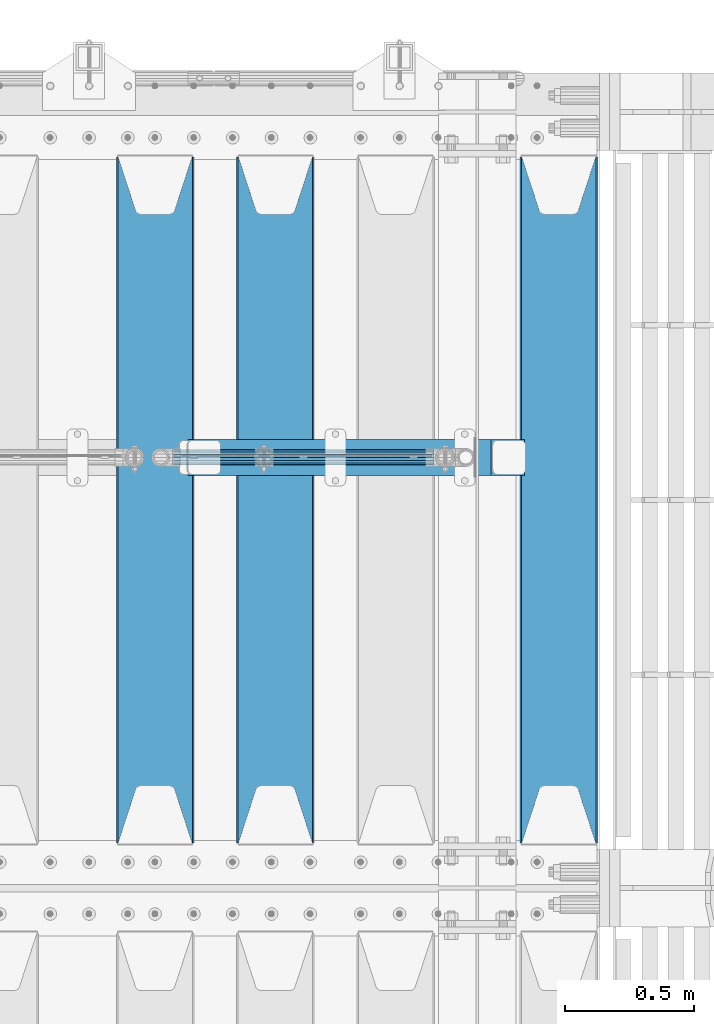
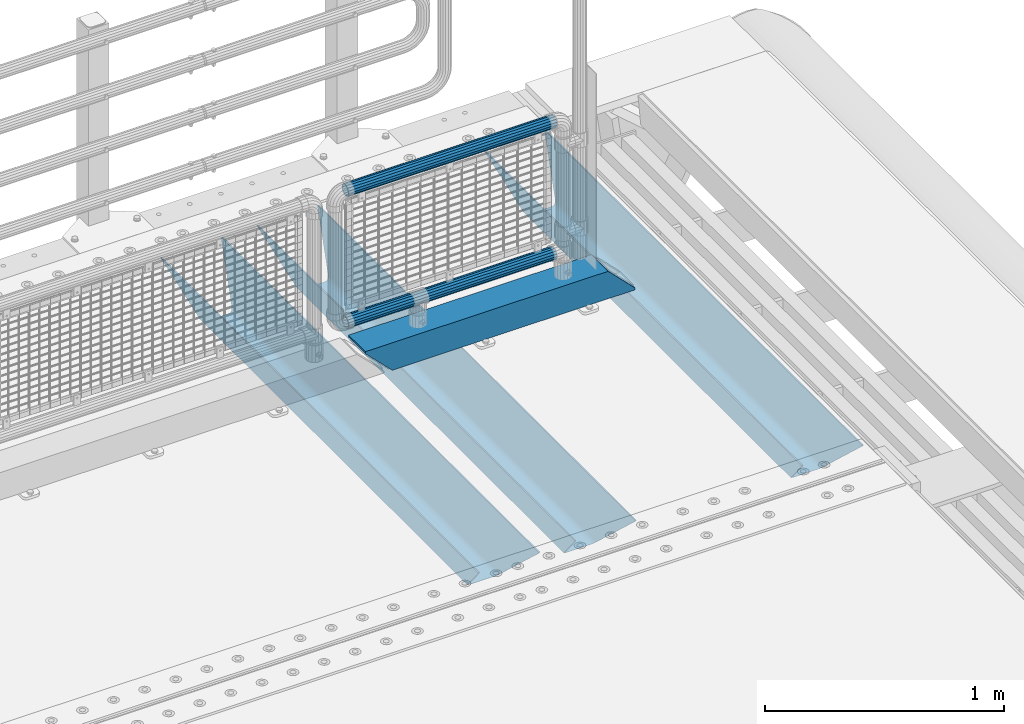
# One storey, part 134 of 257: 6 beams.
"""IFC2X3 building model written with IfcOpenShell, lengths in millimetres."""

from ifc_helpers import new_model, si_unit, frame, origin_with_axes, place, context, subcontext, project, spatial, faceted_brep, material, type_object, element, save


model = new_model("IFC2X3")

# Units and contexts
model_context = context("Model", 3, precision=1e-05, world=origin_with_axes())
body_context = subcontext(model_context, "Body", "Model", "MODEL_VIEW")
ifc_project = project(units=[si_unit("LENGTHUNIT", "METRE", prefix="MILLI"), si_unit("AREAUNIT", "SQUARE_METRE"), si_unit("VOLUMEUNIT", "CUBIC_METRE"), si_unit("MASSUNIT", "GRAM", prefix="KILO"), si_unit("TIMEUNIT", "SECOND"), si_unit("PLANEANGLEUNIT", "RADIAN"), si_unit("SOLIDANGLEUNIT", "STERADIAN"), si_unit("THERMODYNAMICTEMPERATUREUNIT", "DEGREE_CELSIUS"), si_unit("LUMINOUSINTENSITYUNIT", "LUMEN")], contexts=[model_context])

# Site, building, storey
site_placement = place(None, origin_with_axes())
site = spatial("IfcSite", under=ifc_project, at=site_placement, CompositionType="ELEMENT")
building_placement = place(site_placement, origin_with_axes())
building = spatial("IfcBuilding", under=site, at=building_placement, Name="Standard", CompositionType="ELEMENT")
storey_placement = place(building_placement, origin_with_axes())
storey = spatial("IfcBuildingStorey", under=building, at=storey_placement, Name="Undefined", CompositionType="ELEMENT", Elevation=0.0)

# Beams
ifc_material_1 = material(Name="STEEL/S355N")
beam_type_1 = type_object("IfcBeamType", PredefinedType="NOTDEFINED")
beam_1_placement = place(storey_placement, frame((59110.0, 9175.0, -115.0), z_axis=(0.0, 0.0, 1.0), x_axis=(0.0, 1.0, 0.0)))
element("IfcBeam", 1, at=beam_1_placement, inside=storey, type_object=beam_type_1, material=ifc_material_1, context=body_context, shape_type="Brep", body=[
    faceted_brep([(0.0, 150.0, 115.0), (0.0, 143.690000000002, 115.0), (2650.00000000297, 143.690000000002, 115.0), (2650.00000000297, 150.0, 115.0), (2650.00000000297, 142.059565218406, 110.0000000031), (2650.00000000297, 148.369565218403, 110.0000000031), (2441.90079219208, -80.1103600731149, -98.0992078077845), (2437.7588105432, -77.5672621345584, -102.241189456673), (2434.06523489746, -74.4080125315522, -105.934765102404), (2430.91086095089, -70.7102721255724, -109.089139048974), (2428.37322971128, -66.5649389910031, -111.626770288588), (2426.51472138055, -62.0739139532889, -113.485278619323), (2425.38102192091, -57.3475956567636, -114.618978078955), (2424.99999999987, -52.5021667386536, -115.0), (2424.99999999987, 52.5021667386536, -115.0), (2425.38102192091, 57.3475956567636, -114.618978078955), (2426.51472138055, 62.0739139532889, -113.485278619323), (2428.37322971128, 66.5649389910031, -111.626770288588), (2430.91086095089, 70.7102721255724, -109.089139048974), (2434.06523489746, 74.4080125315522, -105.934765102404), (2437.7588105432, 77.5672621345584, -102.241189456673), (2441.90079219208, 80.1103600731149, -98.0992078077846), (2446.38936140511, 81.9747917625791, -93.6106385947584), (2448.24948500409, 76.2713538057287, -91.7505149957729), (2444.62967112262, 74.76777986261, -95.3703288772456), (2441.28936334126, 72.7168944282894, -98.710636658607), (2438.31067330438, 70.1691124903809, -101.689326695487), (2435.76682334747, 67.1870637758839, -104.233176652398), (2433.72034654133, 63.8440531834931, -106.279653458539), (2432.22154950041, 60.2222587982324, -107.778450499454), (2431.30727574265, 56.4107117849126, -108.692724257221), (2430.99999999987, 52.5031078186876, -109.0), (2430.99999999987, -52.5031078186876, -109.0), (2431.30727574265, -56.4107117849126, -108.692724257221), (2432.22154950041, -60.2222587982324, -107.778450499454), (2433.72034654133, -63.8440531834931, -106.279653458539), (2435.76682334747, -67.1870637758839, -104.233176652398), (2438.31067330438, -70.1691124903809, -101.689326695487), (2441.28936334126, -72.7168944282894, -98.7106366586071), (2444.62967112262, -74.76777986261, -95.3703288772457), (2448.24948500409, -76.2713538057287, -91.7505149957729), (2650.00000000297, -142.059565218406, 110.0000000031), (2650.00000000297, -148.369565218403, 110.0000000031), (2446.38936140511, -81.9747917625791, -93.6106385947584), (2650.00000000297, -143.690000000002, 115.0), (2650.00000000297, -150.0, 115.0), (0.0, -143.690000000002, 115.0), (0.0, -150.0, 115.0), (0.0, -148.369565218258, 110.000000002662), (203.61063859742, -81.9747917625791, -93.6106385947584), (208.099207810447, -80.1103600731149, -98.0992078077845), (212.241189459335, -77.5672621345584, -102.241189456673), (215.934765105066, -74.4080125315522, -105.934765102404), (219.089139051636, -70.7102721255724, -109.089139048974), (221.626770291251, -66.5649389910031, -111.626770288588), (223.485278621985, -62.0739139532889, -113.485278619323), (224.618978081617, -57.3475956567636, -114.618978078955), (225.000000002662, -52.5021667386536, -115.0), (225.000000002662, 52.5021667386536, -115.0), (224.618978081617, 57.3475956567636, -114.618978078955), (223.485278621985, 62.0739139532889, -113.485278619323), (221.626770291251, 66.5649389910031, -111.626770288588), (219.089139051636, 70.7102721255724, -109.089139048974), (215.934765105066, 74.4080125315522, -105.934765102404), (212.241189459335, 77.5672621345584, -102.241189456673), (208.099207810447, 80.1103600731149, -98.0992078077846), (203.61063859742, 81.9747917625791, -93.6106385947584), (0.0, 148.369565218258, 110.000000002662), (0.0, 142.05956521826, 110.000000002662), (201.750514998435, 76.2713538057287, -91.7505149957729), (205.370328879908, 74.76777986261, -95.3703288772456), (208.710636661269, 72.7168944282894, -98.710636658607), (211.689326698149, 70.1691124903809, -101.689326695487), (214.233176655061, 67.1870637758839, -104.233176652398), (216.279653461201, 63.8440531834931, -106.279653458539), (217.778450502116, 60.2222587982324, -107.778450499454), (218.692724259884, 56.4107117849126, -108.692724257221), (219.000000002662, 52.5031078186876, -109.0), (219.000000002662, -52.5031078186876, -109.0), (218.692724259884, -56.4107117849126, -108.692724257221), (217.778450502116, -60.2222587982324, -107.778450499454), (216.279653461201, -63.8440531834931, -106.279653458539), (214.233176655061, -67.1870637758839, -104.233176652398), (211.689326698149, -70.1691124903809, -101.689326695487), (208.710636661269, -72.7168944282894, -98.7106366586071), (205.370328879908, -74.76777986261, -95.3703288772457), (201.750514998435, -76.2713538057287, -91.7505149957729), (0.0, -142.05956521826, 110.000000002662)], [[[0, 1, 2, 3]], [[3, 2, 4, 5]], [[6, 7, 8, 9, 10, 11, 12, 13, 14, 15, 16, 17, 18, 19, 20, 21, 22, 5, 4, 23, 24, 25, 26, 27, 28, 29, 30, 31, 32, 33, 34, 35, 36, 37, 38, 39, 40, 41, 42, 43]], [[44, 45, 42, 41]], [[46, 47, 45, 44]], [[43, 42, 45, 47, 48, 49]], [[6, 43, 49, 50]], [[7, 6, 50, 51]], [[8, 7, 51, 52]], [[9, 8, 52, 53]], [[10, 9, 53, 54]], [[11, 10, 54, 55]], [[12, 11, 55, 56]], [[13, 12, 56, 57]], [[14, 13, 57, 58]], [[15, 14, 58, 59]], [[16, 15, 59, 60]], [[17, 16, 60, 61]], [[18, 17, 61, 62]], [[19, 18, 62, 63]], [[20, 19, 63, 64]], [[21, 20, 64, 65]], [[22, 21, 65, 66]], [[0, 3, 5, 22, 66, 67]], [[1, 0, 67, 68]], [[23, 4, 2, 1, 68, 69]], [[24, 23, 69, 70]], [[25, 24, 70, 71]], [[26, 25, 71, 72]], [[27, 26, 72, 73]], [[28, 27, 73, 74]], [[29, 28, 74, 75]], [[30, 29, 75, 76]], [[31, 30, 76, 77]], [[32, 31, 77, 78]], [[33, 32, 78, 79]], [[34, 33, 79, 80]], [[35, 34, 80, 81]], [[36, 35, 81, 82]], [[37, 36, 82, 83]], [[38, 37, 83, 84]], [[39, 38, 84, 85]], [[40, 39, 85, 86]], [[46, 44, 41, 40, 86, 87]], [[47, 46, 87, 48]], [[86, 85, 84, 83, 82, 81, 80, 79, 78, 77, 76, 75, 74, 73, 72, 71, 70, 69, 68, 67, 66, 65, 64, 63, 62, 61, 60, 59, 58, 57, 56, 55, 54, 53, 52, 51, 50, 49, 48, 87]]]),
])
beam_2_placement = place(storey_placement, frame((58015.0, 9175.0, -115.0), z_axis=(0.0, 0.0, 1.0), x_axis=(0.0, 1.0, 0.0)))
element("IfcBeam", 2, at=beam_2_placement, inside=storey, type_object=beam_type_1, material=ifc_material_1, context=body_context, shape_type="Brep", body=[
    faceted_brep([(0.0, 150.0, 115.0), (0.0, 143.690000000002, 115.0), (2650.00000000297, 143.690000000002, 115.0), (2650.00000000297, 150.0, 115.0), (2650.00000000297, 142.059565218406, 110.0000000031), (2650.00000000297, 148.369565218403, 110.0000000031), (2441.90079219208, -80.1103600731149, -98.0992078077845), (2437.7588105432, -77.5672621345584, -102.241189456673), (2434.06523489746, -74.4080125315522, -105.934765102404), (2430.91086095089, -70.7102721255724, -109.089139048974), (2428.37322971128, -66.5649389910031, -111.626770288588), (2426.51472138055, -62.0739139532889, -113.485278619323), (2425.38102192091, -57.3475956567636, -114.618978078955), (2424.99999999987, -52.5021667386536, -115.0), (2424.99999999987, 52.5021667386536, -115.0), (2425.38102192091, 57.3475956567636, -114.618978078955), (2426.51472138055, 62.0739139532889, -113.485278619323), (2428.37322971128, 66.5649389910031, -111.626770288588), (2430.91086095089, 70.7102721255724, -109.089139048974), (2434.06523489746, 74.4080125315522, -105.934765102404), (2437.7588105432, 77.5672621345584, -102.241189456673), (2441.90079219208, 80.1103600731149, -98.0992078077846), (2446.38936140511, 81.9747917625791, -93.6106385947584), (2448.24948500409, 76.2713538057287, -91.7505149957729), (2444.62967112262, 74.76777986261, -95.3703288772456), (2441.28936334126, 72.7168944282894, -98.710636658607), (2438.31067330438, 70.1691124903809, -101.689326695487), (2435.76682334747, 67.1870637758839, -104.233176652398), (2433.72034654133, 63.8440531834931, -106.279653458539), (2432.22154950041, 60.2222587982324, -107.778450499454), (2431.30727574265, 56.4107117849126, -108.692724257221), (2430.99999999987, 52.5031078186876, -109.0), (2430.99999999987, -52.5031078186876, -109.0), (2431.30727574265, -56.4107117849126, -108.692724257221), (2432.22154950041, -60.2222587982324, -107.778450499454), (2433.72034654133, -63.8440531834931, -106.279653458539), (2435.76682334747, -67.1870637758839, -104.233176652398), (2438.31067330438, -70.1691124903809, -101.689326695487), (2441.28936334126, -72.7168944282894, -98.7106366586071), (2444.62967112262, -74.76777986261, -95.3703288772457), (2448.24948500409, -76.2713538057287, -91.7505149957729), (2650.00000000297, -142.059565218406, 110.0000000031), (2650.00000000297, -148.369565218403, 110.0000000031), (2446.38936140511, -81.9747917625791, -93.6106385947584), (2650.00000000297, -143.690000000002, 115.0), (2650.00000000297, -150.0, 115.0), (0.0, -143.690000000002, 115.0), (0.0, -150.0, 115.0), (0.0, -148.369565218258, 110.000000002662), (203.61063859742, -81.9747917625791, -93.6106385947584), (208.099207810447, -80.1103600731149, -98.0992078077845), (212.241189459335, -77.5672621345584, -102.241189456673), (215.934765105066, -74.4080125315522, -105.934765102404), (219.089139051636, -70.7102721255724, -109.089139048974), (221.626770291251, -66.5649389910031, -111.626770288588), (223.485278621985, -62.0739139532889, -113.485278619323), (224.618978081617, -57.3475956567636, -114.618978078955), (225.000000002662, -52.5021667386536, -115.0), (225.000000002662, 52.5021667386536, -115.0), (224.618978081617, 57.3475956567636, -114.618978078955), (223.485278621985, 62.0739139532889, -113.485278619323), (221.626770291251, 66.5649389910031, -111.626770288588), (219.089139051636, 70.7102721255724, -109.089139048974), (215.934765105066, 74.4080125315522, -105.934765102404), (212.241189459335, 77.5672621345584, -102.241189456673), (208.099207810447, 80.1103600731149, -98.0992078077846), (203.61063859742, 81.9747917625791, -93.6106385947584), (0.0, 148.369565218258, 110.000000002662), (0.0, 142.05956521826, 110.000000002662), (201.750514998435, 76.2713538057287, -91.7505149957729), (205.370328879908, 74.76777986261, -95.3703288772456), (208.710636661269, 72.7168944282894, -98.710636658607), (211.689326698149, 70.1691124903809, -101.689326695487), (214.233176655061, 67.1870637758839, -104.233176652398), (216.279653461201, 63.8440531834931, -106.279653458539), (217.778450502116, 60.2222587982324, -107.778450499454), (218.692724259884, 56.4107117849126, -108.692724257221), (219.000000002662, 52.5031078186876, -109.0), (219.000000002662, -52.5031078186876, -109.0), (218.692724259884, -56.4107117849126, -108.692724257221), (217.778450502116, -60.2222587982324, -107.778450499454), (216.279653461201, -63.8440531834931, -106.279653458539), (214.233176655061, -67.1870637758839, -104.233176652398), (211.689326698149, -70.1691124903809, -101.689326695487), (208.710636661269, -72.7168944282894, -98.7106366586071), (205.370328879908, -74.76777986261, -95.3703288772457), (201.750514998435, -76.2713538057287, -91.7505149957729), (0.0, -142.05956521826, 110.000000002662)], [[[0, 1, 2, 3]], [[3, 2, 4, 5]], [[6, 7, 8, 9, 10, 11, 12, 13, 14, 15, 16, 17, 18, 19, 20, 21, 22, 5, 4, 23, 24, 25, 26, 27, 28, 29, 30, 31, 32, 33, 34, 35, 36, 37, 38, 39, 40, 41, 42, 43]], [[44, 45, 42, 41]], [[46, 47, 45, 44]], [[43, 42, 45, 47, 48, 49]], [[6, 43, 49, 50]], [[7, 6, 50, 51]], [[8, 7, 51, 52]], [[9, 8, 52, 53]], [[10, 9, 53, 54]], [[11, 10, 54, 55]], [[12, 11, 55, 56]], [[13, 12, 56, 57]], [[14, 13, 57, 58]], [[15, 14, 58, 59]], [[16, 15, 59, 60]], [[17, 16, 60, 61]], [[18, 17, 61, 62]], [[19, 18, 62, 63]], [[20, 19, 63, 64]], [[21, 20, 64, 65]], [[22, 21, 65, 66]], [[0, 3, 5, 22, 66, 67]], [[1, 0, 67, 68]], [[23, 4, 2, 1, 68, 69]], [[24, 23, 69, 70]], [[25, 24, 70, 71]], [[26, 25, 71, 72]], [[27, 26, 72, 73]], [[28, 27, 73, 74]], [[29, 28, 74, 75]], [[30, 29, 75, 76]], [[31, 30, 76, 77]], [[32, 31, 77, 78]], [[33, 32, 78, 79]], [[34, 33, 79, 80]], [[35, 34, 80, 81]], [[36, 35, 81, 82]], [[37, 36, 82, 83]], [[38, 37, 83, 84]], [[39, 38, 84, 85]], [[40, 39, 85, 86]], [[46, 44, 41, 40, 86, 87]], [[47, 46, 87, 48]], [[86, 85, 84, 83, 82, 81, 80, 79, 78, 77, 76, 75, 74, 73, 72, 71, 70, 69, 68, 67, 66, 65, 64, 63, 62, 61, 60, 59, 58, 57, 56, 55, 54, 53, 52, 51, 50, 49, 48, 87]]]),
])
beam_3_placement = place(storey_placement, frame((57550.0, 9175.0, -115.0), z_axis=(0.0, 0.0, 1.0), x_axis=(0.0, 1.0, 0.0)))
element("IfcBeam", 3, at=beam_3_placement, inside=storey, type_object=beam_type_1, material=ifc_material_1, context=body_context, shape_type="Brep", body=[
    faceted_brep([(0.0, 150.0, 115.0), (0.0, 143.690000000002, 115.0), (2650.00000000297, 143.690000000002, 115.0), (2650.00000000297, 150.0, 115.0), (2650.00000000297, 142.059565218406, 110.0000000031), (2650.00000000297, 148.369565218403, 110.0000000031), (2441.90079219208, -80.1103600731149, -98.0992078077845), (2437.7588105432, -77.5672621345584, -102.241189456673), (2434.06523489746, -74.4080125315522, -105.934765102404), (2430.91086095089, -70.7102721255724, -109.089139048974), (2428.37322971128, -66.5649389910031, -111.626770288588), (2426.51472138055, -62.0739139532889, -113.485278619323), (2425.38102192091, -57.3475956567636, -114.618978078955), (2424.99999999987, -52.5021667386536, -115.0), (2424.99999999987, 52.5021667386536, -115.0), (2425.38102192091, 57.3475956567636, -114.618978078955), (2426.51472138055, 62.0739139532889, -113.485278619323), (2428.37322971128, 66.5649389910031, -111.626770288588), (2430.91086095089, 70.7102721255724, -109.089139048974), (2434.06523489746, 74.4080125315522, -105.934765102404), (2437.7588105432, 77.5672621345584, -102.241189456673), (2441.90079219208, 80.1103600731149, -98.0992078077846), (2446.38936140511, 81.9747917625791, -93.6106385947584), (2448.24948500409, 76.2713538057287, -91.7505149957729), (2444.62967112262, 74.76777986261, -95.3703288772456), (2441.28936334126, 72.7168944282894, -98.710636658607), (2438.31067330438, 70.1691124903809, -101.689326695487), (2435.76682334747, 67.1870637758839, -104.233176652398), (2433.72034654133, 63.8440531834931, -106.279653458539), (2432.22154950041, 60.2222587982324, -107.778450499454), (2431.30727574265, 56.4107117849126, -108.692724257221), (2430.99999999987, 52.5031078186876, -109.0), (2430.99999999987, -52.5031078186876, -109.0), (2431.30727574265, -56.4107117849126, -108.692724257221), (2432.22154950041, -60.2222587982324, -107.778450499454), (2433.72034654133, -63.8440531834931, -106.279653458539), (2435.76682334747, -67.1870637758839, -104.233176652398), (2438.31067330438, -70.1691124903809, -101.689326695487), (2441.28936334126, -72.7168944282894, -98.7106366586071), (2444.62967112262, -74.76777986261, -95.3703288772457), (2448.24948500409, -76.2713538057287, -91.7505149957729), (2650.00000000297, -142.059565218406, 110.0000000031), (2650.00000000297, -148.369565218403, 110.0000000031), (2446.38936140511, -81.9747917625791, -93.6106385947584), (2650.00000000297, -143.690000000002, 115.0), (2650.00000000297, -150.0, 115.0), (0.0, -143.690000000002, 115.0), (0.0, -150.0, 115.0), (0.0, -148.369565218258, 110.000000002662), (203.61063859742, -81.9747917625791, -93.6106385947584), (208.099207810447, -80.1103600731149, -98.0992078077845), (212.241189459335, -77.5672621345584, -102.241189456673), (215.934765105066, -74.4080125315522, -105.934765102404), (219.089139051636, -70.7102721255724, -109.089139048974), (221.626770291251, -66.5649389910031, -111.626770288588), (223.485278621985, -62.0739139532889, -113.485278619323), (224.618978081617, -57.3475956567636, -114.618978078955), (225.000000002662, -52.5021667386536, -115.0), (225.000000002662, 52.5021667386536, -115.0), (224.618978081617, 57.3475956567636, -114.618978078955), (223.485278621985, 62.0739139532889, -113.485278619323), (221.626770291251, 66.5649389910031, -111.626770288588), (219.089139051636, 70.7102721255724, -109.089139048974), (215.934765105066, 74.4080125315522, -105.934765102404), (212.241189459335, 77.5672621345584, -102.241189456673), (208.099207810447, 80.1103600731149, -98.0992078077846), (203.61063859742, 81.9747917625791, -93.6106385947584), (0.0, 148.369565218258, 110.000000002662), (0.0, 142.05956521826, 110.000000002662), (201.750514998435, 76.2713538057287, -91.7505149957729), (205.370328879908, 74.76777986261, -95.3703288772456), (208.710636661269, 72.7168944282894, -98.710636658607), (211.689326698149, 70.1691124903809, -101.689326695487), (214.233176655061, 67.1870637758839, -104.233176652398), (216.279653461201, 63.8440531834931, -106.279653458539), (217.778450502116, 60.2222587982324, -107.778450499454), (218.692724259884, 56.4107117849126, -108.692724257221), (219.000000002662, 52.5031078186876, -109.0), (219.000000002662, -52.5031078186876, -109.0), (218.692724259884, -56.4107117849126, -108.692724257221), (217.778450502116, -60.2222587982324, -107.778450499454), (216.279653461201, -63.8440531834931, -106.279653458539), (214.233176655061, -67.1870637758839, -104.233176652398), (211.689326698149, -70.1691124903809, -101.689326695487), (208.710636661269, -72.7168944282894, -98.7106366586071), (205.370328879908, -74.76777986261, -95.3703288772457), (201.750514998435, -76.2713538057287, -91.7505149957729), (0.0, -142.05956521826, 110.000000002662)], [[[0, 1, 2, 3]], [[3, 2, 4, 5]], [[6, 7, 8, 9, 10, 11, 12, 13, 14, 15, 16, 17, 18, 19, 20, 21, 22, 5, 4, 23, 24, 25, 26, 27, 28, 29, 30, 31, 32, 33, 34, 35, 36, 37, 38, 39, 40, 41, 42, 43]], [[44, 45, 42, 41]], [[46, 47, 45, 44]], [[43, 42, 45, 47, 48, 49]], [[6, 43, 49, 50]], [[7, 6, 50, 51]], [[8, 7, 51, 52]], [[9, 8, 52, 53]], [[10, 9, 53, 54]], [[11, 10, 54, 55]], [[12, 11, 55, 56]], [[13, 12, 56, 57]], [[14, 13, 57, 58]], [[15, 14, 58, 59]], [[16, 15, 59, 60]], [[17, 16, 60, 61]], [[18, 17, 61, 62]], [[19, 18, 62, 63]], [[20, 19, 63, 64]], [[21, 20, 64, 65]], [[22, 21, 65, 66]], [[0, 3, 5, 22, 66, 67]], [[1, 0, 67, 68]], [[23, 4, 2, 1, 68, 69]], [[24, 23, 69, 70]], [[25, 24, 70, 71]], [[26, 25, 71, 72]], [[27, 26, 72, 73]], [[28, 27, 73, 74]], [[29, 28, 74, 75]], [[30, 29, 75, 76]], [[31, 30, 76, 77]], [[32, 31, 77, 78]], [[33, 32, 78, 79]], [[34, 33, 79, 80]], [[35, 34, 80, 81]], [[36, 35, 81, 82]], [[37, 36, 82, 83]], [[38, 37, 83, 84]], [[39, 38, 84, 85]], [[40, 39, 85, 86]], [[46, 44, 41, 40, 86, 87]], [[47, 46, 87, 48]], [[86, 85, 84, 83, 82, 81, 80, 79, 78, 77, 76, 75, 74, 73, 72, 71, 70, 69, 68, 67, 66, 65, 64, 63, 62, 61, 60, 59, 58, 57, 56, 55, 54, 53, 52, 51, 50, 49, 48, 87]]]),
])
ifc_material_2 = material()
beam_type_2 = type_object("IfcBeamType", PredefinedType="NOTDEFINED")
beam_4_placement = place(storey_placement, frame((57677.0, 10664.5, 98.0199999999977), z_axis=(0.0, 0.0, 1.0), x_axis=(1.0, 0.0, 0.0)))
element("IfcBeam", 4, at=beam_4_placement, inside=storey, type_object=beam_type_2, material=ifc_material_2, context=body_context, shape_type="Brep", body=[
    faceted_brep([(0.0, 70.0, 70.0), (0.0, -70.0, 70.0), (1170.88846984783, -70.0, 70.0), (1170.88846984783, 70.0, 70.0), (1301.0, -60.0, -60.0), (1301.0, 60.0, -60.0), (119.989831466446, 60.0, -60.0), (119.98991062618, -60.0, -60.0), (1180.89643628727, -60.0, 60.0), (2.49929499318569e-09, -59.9999999999991, 60.0), (2.49929144047201e-09, 60.0000000000005, 60.0), (1180.89643628727, 60.0, 60.0), (1301.0, -70.0, -60.0079600980695), (1301.0, 70.0, -60.0079600980695), (1301.0, -70.0, -70.0), (1301.0, 70.0, -70.0), (129.999907566686, 70.0, -70.0), (0.0, 70.0, 59.868964626168), (0.0, -70.0, 59.8690568861672), (129.99999991971, -70.0, -70.0)], [[[0, 1, 2, 3]], [[4, 5, 6, 7]], [[8, 4, 7, 9]], [[9, 10, 11, 8]], [[5, 11, 10, 6]], [[2, 12, 4, 8, 11, 5, 13, 3]], [[4, 12, 14, 15, 13, 5]], [[0, 3, 13, 15, 16, 17]], [[9, 18, 1, 0, 17, 10]], [[14, 12, 2, 1, 18, 19]], [[15, 14, 19, 16]], [[18, 9, 7, 6, 10, 17, 16, 19]]]),
])
beam_type_3 = type_object("IfcBeamType", PredefinedType="NOTDEFINED")
beam_5_placement = place(storey_placement, frame((57621.6, 10664.5, 298.170000000001), z_axis=(0.0, 0.0, 1.0), x_axis=(1.0, 0.0, 0.0)))
element("IfcBeam", 5, at=beam_5_placement, inside=storey, type_object=beam_type_3, material=ifc_material_2, context=body_context, shape_type="Brep", body=[
    faceted_brep([(0.0, -25.3500000000004, 0.0), (0.0, -23.4203461491616, 9.70102501045767), (1005.0, -23.4203461491616, 9.70102501045506), (1005.0, -25.3500000000004, 0.0), (0.0, -17.9251569030785, 17.9251569030821), (1005.0, -17.9251569030785, 17.925156903079), (0.0, -9.70102501045585, 23.4203461491634), (1005.0, -9.70102501045585, 23.4203461491611), (0.0, 0.0, 25.3499999999985), (1005.0, 0.0, 25.35), (0.0, 9.70102501045585, 23.4203461491634), (1005.0, 9.70102501045585, 23.4203461491611), (0.0, 17.9251569030785, 17.9251569030821), (1005.0, 17.9251569030785, 17.925156903079), (0.0, 23.4203461491616, 9.70102501045767), (1005.0, 23.4203461491616, 9.701025010455), (0.0, 25.3500000000004, 0.0), (1005.0, 25.3500000000004, 0.0), (0.0, 23.4203461491616, -9.70102501045767), (1005.0, 23.4203461491616, -9.70102501045506), (0.0, 17.9251569030785, -17.9251569030821), (1005.0, 17.9251569030785, -17.925156903079), (0.0, 9.70102501045585, -23.4203461491634), (1005.0, 9.70102501045585, -23.4203461491611), (0.0, 0.0, -25.3499999999985), (1005.0, 0.0, -25.35), (0.0, -9.70102501045585, -23.4203461491634), (1005.0, -9.70102501045585, -23.4203461491611), (0.0, -17.9251569030785, -17.9251569030821), (1005.0, -17.9251569030785, -17.925156903079), (0.0, -23.4203461491616, -9.70102501045767), (1005.0, -23.4203461491616, -9.701025010455), (0.0, -30.1499999999996, 0.0), (0.0, -27.8549679052157, -11.5379054858058), (1005.0, -27.8549679052157, -11.5379054858075), (1005.0, -30.1499999999996, 0.0), (0.0, -21.3192694527752, -21.3192694527752), (1005.0, -21.3192694527752, -21.3192694527744), (0.0, -11.5379054858076, -27.8549679052157), (1005.0, -11.5379054858076, -27.8549679052153), (0.0, 0.0, -30.1500000000015), (1005.0, 0.0, -30.15), (0.0, 11.5379054858076, -27.8549679052157), (1005.0, 11.5379054858076, -27.8549679052153), (0.0, 21.3192694527752, -21.3192694527752), (1005.0, 21.3192694527752, -21.3192694527744), (0.0, 27.8549679052157, -11.5379054858058), (1005.0, 27.8549679052157, -11.5379054858075), (0.0, 30.1499999999996, 0.0), (1005.0, 30.1499999999996, 0.0), (0.0, 27.8549679052157, 11.5379054858058), (1005.0, 27.8549679052157, 11.5379054858075), (0.0, 21.3192694527752, 21.3192694527752), (1005.0, 21.3192694527752, 21.3192694527744), (0.0, 11.5379054858076, 27.8549679052157), (1005.0, 11.5379054858076, 27.8549679052153), (0.0, 0.0, 30.1500000000015), (1005.0, 0.0, 30.15), (0.0, -11.5379054858076, 27.8549679052157), (1005.0, -11.5379054858076, 27.8549679052153), (0.0, -21.3192694527752, 21.3192694527752), (1005.0, -21.3192694527752, 21.3192694527744), (0.0, -27.8549679052157, 11.5379054858058), (1005.0, -27.8549679052157, 11.5379054858075)], [[[0, 1, 2, 3]], [[1, 4, 5, 2]], [[4, 6, 7, 5]], [[6, 8, 9, 7]], [[8, 10, 11, 9]], [[10, 12, 13, 11]], [[12, 14, 15, 13]], [[14, 16, 17, 15]], [[16, 18, 19, 17]], [[18, 20, 21, 19]], [[20, 22, 23, 21]], [[22, 24, 25, 23]], [[24, 26, 27, 25]], [[26, 28, 29, 27]], [[28, 30, 31, 29]], [[30, 0, 3, 31]], [[32, 33, 34, 35]], [[33, 36, 37, 34]], [[36, 38, 39, 37]], [[38, 40, 41, 39]], [[40, 42, 43, 41]], [[42, 44, 45, 43]], [[44, 46, 47, 45]], [[46, 48, 49, 47]], [[48, 50, 51, 49]], [[50, 52, 53, 51]], [[52, 54, 55, 53]], [[54, 56, 57, 55]], [[56, 58, 59, 57]], [[58, 60, 61, 59]], [[60, 62, 63, 61]], [[62, 32, 35, 63]], [[37, 39, 41, 43, 45, 47, 49, 51, 53, 55, 57, 59, 61, 63, 35, 34], [5, 7, 9, 11, 13, 15, 17, 19, 21, 23, 25, 27, 29, 31, 3, 2]], [[62, 60, 58, 56, 54, 52, 50, 48, 46, 44, 42, 40, 38, 36, 33, 32], [30, 28, 26, 24, 22, 20, 18, 16, 14, 12, 10, 8, 6, 4, 1, 0]]]),
])
beam_6_placement = place(storey_placement, frame((57621.0, 10664.5, 969.85), z_axis=(0.0, 0.0, 1.0), x_axis=(1.0, 0.0, 0.0)))
element("IfcBeam", 6, at=beam_6_placement, inside=storey, type_object=beam_type_3, material=ifc_material_2, context=body_context, shape_type="Brep", body=[
    faceted_brep([(0.0, -25.3500000000004, 0.0), (0.0, -23.4203461491616, 9.70102501045767), (1005.0, -23.4203461491616, 9.70102501045506), (1005.0, -25.3500000000004, 0.0), (0.0, -17.9251569030785, 17.9251569030821), (1005.0, -17.9251569030785, 17.925156903079), (0.0, -9.70102501045585, 23.4203461491634), (1005.0, -9.70102501045585, 23.4203461491611), (0.0, 0.0, 25.3499999999985), (1005.0, 0.0, 25.35), (0.0, 9.70102501045585, 23.4203461491634), (1005.0, 9.70102501045585, 23.4203461491611), (0.0, 17.9251569030785, 17.9251569030821), (1005.0, 17.9251569030785, 17.925156903079), (0.0, 23.4203461491616, 9.70102501045767), (1005.0, 23.4203461491616, 9.701025010455), (0.0, 25.3500000000004, 0.0), (1005.0, 25.3500000000004, 0.0), (0.0, 23.4203461491616, -9.70102501045767), (1005.0, 23.4203461491616, -9.70102501045506), (0.0, 17.9251569030785, -17.9251569030821), (1005.0, 17.9251569030785, -17.925156903079), (0.0, 9.70102501045585, -23.4203461491634), (1005.0, 9.70102501045585, -23.4203461491611), (0.0, 0.0, -25.3499999999985), (1005.0, 0.0, -25.35), (0.0, -9.70102501045585, -23.4203461491634), (1005.0, -9.70102501045585, -23.4203461491611), (0.0, -17.9251569030785, -17.9251569030821), (1005.0, -17.9251569030785, -17.925156903079), (0.0, -23.4203461491616, -9.70102501045767), (1005.0, -23.4203461491616, -9.701025010455), (0.0, -30.1499999999996, 0.0), (0.0, -27.8549679052157, -11.5379054858058), (1005.0, -27.8549679052157, -11.5379054858075), (1005.0, -30.1499999999996, 0.0), (0.0, -21.3192694527752, -21.3192694527752), (1005.0, -21.3192694527752, -21.3192694527744), (0.0, -11.5379054858076, -27.8549679052157), (1005.0, -11.5379054858076, -27.8549679052153), (0.0, 0.0, -30.1500000000015), (1005.0, 0.0, -30.15), (0.0, 11.5379054858076, -27.8549679052157), (1005.0, 11.5379054858076, -27.8549679052153), (0.0, 21.3192694527752, -21.3192694527752), (1005.0, 21.3192694527752, -21.3192694527744), (0.0, 27.8549679052157, -11.5379054858058), (1005.0, 27.8549679052157, -11.5379054858075), (0.0, 30.1499999999996, 0.0), (1005.0, 30.1499999999996, 0.0), (0.0, 27.8549679052157, 11.5379054858058), (1005.0, 27.8549679052157, 11.5379054858075), (0.0, 21.3192694527752, 21.3192694527752), (1005.0, 21.3192694527752, 21.3192694527744), (0.0, 11.5379054858076, 27.8549679052157), (1005.0, 11.5379054858076, 27.8549679052153), (0.0, 0.0, 30.1500000000015), (1005.0, 0.0, 30.15), (0.0, -11.5379054858076, 27.8549679052157), (1005.0, -11.5379054858076, 27.8549679052153), (0.0, -21.3192694527752, 21.3192694527752), (1005.0, -21.3192694527752, 21.3192694527744), (0.0, -27.8549679052157, 11.5379054858058), (1005.0, -27.8549679052157, 11.5379054858075)], [[[0, 1, 2, 3]], [[1, 4, 5, 2]], [[4, 6, 7, 5]], [[6, 8, 9, 7]], [[8, 10, 11, 9]], [[10, 12, 13, 11]], [[12, 14, 15, 13]], [[14, 16, 17, 15]], [[16, 18, 19, 17]], [[18, 20, 21, 19]], [[20, 22, 23, 21]], [[22, 24, 25, 23]], [[24, 26, 27, 25]], [[26, 28, 29, 27]], [[28, 30, 31, 29]], [[30, 0, 3, 31]], [[32, 33, 34, 35]], [[33, 36, 37, 34]], [[36, 38, 39, 37]], [[38, 40, 41, 39]], [[40, 42, 43, 41]], [[42, 44, 45, 43]], [[44, 46, 47, 45]], [[46, 48, 49, 47]], [[48, 50, 51, 49]], [[50, 52, 53, 51]], [[52, 54, 55, 53]], [[54, 56, 57, 55]], [[56, 58, 59, 57]], [[58, 60, 61, 59]], [[60, 62, 63, 61]], [[62, 32, 35, 63]], [[37, 39, 41, 43, 45, 47, 49, 51, 53, 55, 57, 59, 61, 63, 35, 34], [5, 7, 9, 11, 13, 15, 17, 19, 21, 23, 25, 27, 29, 31, 3, 2]], [[62, 60, 58, 56, 54, 52, 50, 48, 46, 44, 42, 40, 38, 36, 33, 32], [30, 28, 26, 24, 22, 20, 18, 16, 14, 12, 10, 8, 6, 4, 1, 0]]]),
])

save(model, "model.ifc")
